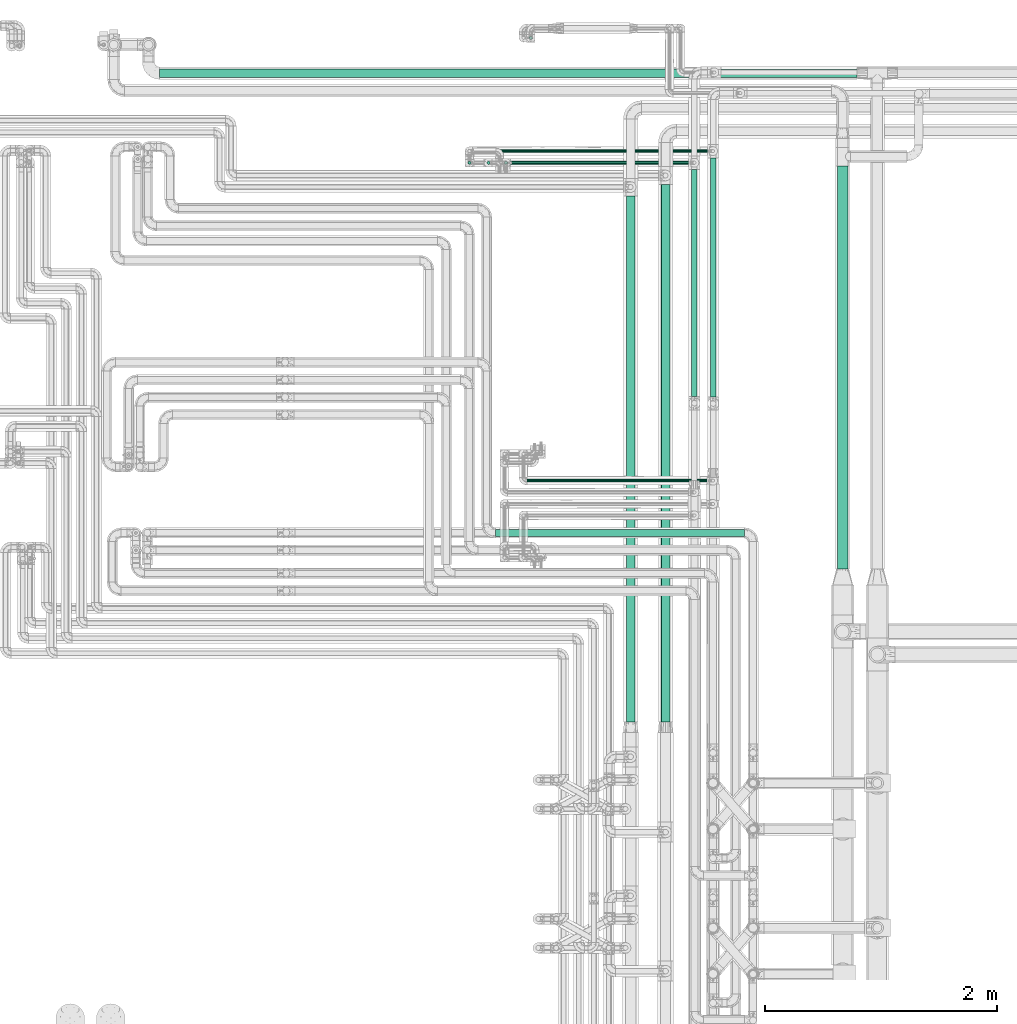
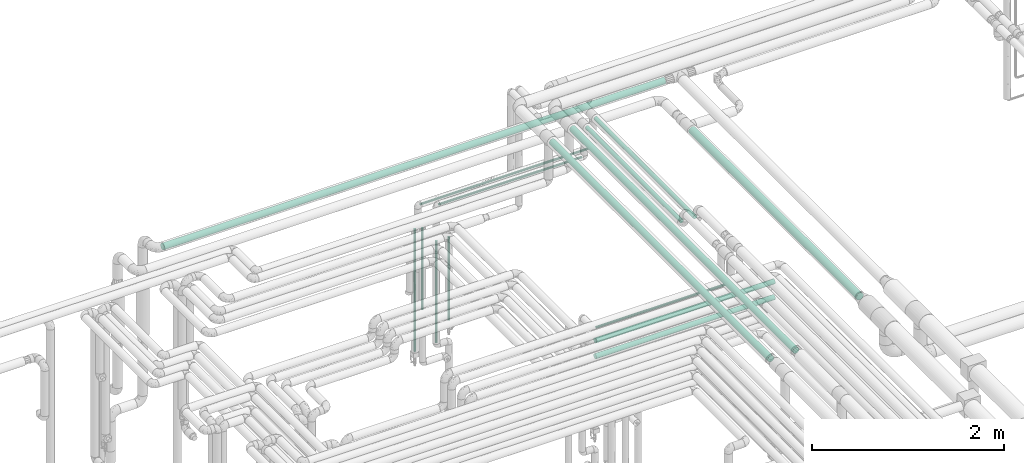
# One storey, part 534 of 827: 15 flow segments.
"""IFC2X3 building model written with IfcOpenShell, lengths in millimetres."""

from ifc_helpers import new_model, entity, si_unit, converted_unit, derived_unit, direction, frame, origin, origin_2d_with_axis, place, context, subcontext, project, spatial, circle, extrude, type_object, element, save


model = new_model("IFC2X3")

# Units and contexts
model_context = context("Model", 3, precision=0.01, world=origin(), true_north=direction((6.12303176911189e-17, 1.0)))
body_context = subcontext(model_context, "Body", "Model", "MODEL_VIEW")
ifc_project = project(units=[si_unit("LENGTHUNIT", "METRE", prefix="MILLI"), si_unit("AREAUNIT", "SQUARE_METRE"), si_unit("VOLUMEUNIT", "CUBIC_METRE"), converted_unit("PLANEANGLEUNIT", "DEGREE", entity("IfcRatioMeasure", 0.0174532925199433), si_unit("PLANEANGLEUNIT", "RADIAN"), dimensions=[0, 0, 0, 0, 0, 0, 0]), si_unit("MASSUNIT", "GRAM", prefix="KILO"), derived_unit("MASSDENSITYUNIT", [(si_unit("MASSUNIT", "GRAM", prefix="KILO"), 1), (si_unit("LENGTHUNIT", "METRE"), -3)]), derived_unit("MOMENTOFINERTIAUNIT", [(si_unit("LENGTHUNIT", "METRE"), 4)]), si_unit("TIMEUNIT", "SECOND"), si_unit("FREQUENCYUNIT", "HERTZ"), si_unit("THERMODYNAMICTEMPERATUREUNIT", "DEGREE_CELSIUS"), derived_unit("THERMALTRANSMITTANCEUNIT", [(si_unit("MASSUNIT", "GRAM", prefix="KILO"), 1), (si_unit("THERMODYNAMICTEMPERATUREUNIT", "KELVIN"), -1), (si_unit("TIMEUNIT", "SECOND"), -3)]), derived_unit("VOLUMETRICFLOWRATEUNIT", [(si_unit("LENGTHUNIT", "METRE"), 3), (si_unit("TIMEUNIT", "SECOND"), -1)]), derived_unit("MASSFLOWRATEUNIT", [(si_unit("MASSUNIT", "GRAM", prefix="KILO"), 1), (si_unit("TIMEUNIT", "SECOND"), -1)]), derived_unit("ROTATIONALFREQUENCYUNIT", [(si_unit("TIMEUNIT", "SECOND"), -1)]), si_unit("ELECTRICCURRENTUNIT", "AMPERE"), si_unit("ELECTRICVOLTAGEUNIT", "VOLT"), si_unit("POWERUNIT", "WATT"), si_unit("FORCEUNIT", "NEWTON", prefix="KILO"), si_unit("ILLUMINANCEUNIT", "LUX"), si_unit("LUMINOUSFLUXUNIT", "LUMEN"), si_unit("LUMINOUSINTENSITYUNIT", "CANDELA"), derived_unit("USERDEFINED", [(si_unit("MASSUNIT", "GRAM", prefix="KILO"), -1), (si_unit("LENGTHUNIT", "METRE"), -2), (si_unit("TIMEUNIT", "SECOND"), 3), (si_unit("LUMINOUSFLUXUNIT", "LUMEN"), 1)]), derived_unit("LINEARVELOCITYUNIT", [(si_unit("LENGTHUNIT", "METRE"), 1), (si_unit("TIMEUNIT", "SECOND"), -1)]), si_unit("PRESSUREUNIT", "PASCAL"), derived_unit("USERDEFINED", [(si_unit("LENGTHUNIT", "METRE"), -2), (si_unit("MASSUNIT", "GRAM", prefix="KILO"), 1), (si_unit("TIMEUNIT", "SECOND"), -2)]), derived_unit("LINEARFORCEUNIT", [(si_unit("MASSUNIT", "GRAM", prefix="KILO"), 1), (si_unit("LENGTHUNIT", "METRE"), 1), (si_unit("TIMEUNIT", "SECOND"), -2), (si_unit("LENGTHUNIT", "METRE"), -1)]), derived_unit("PLANARFORCEUNIT", [(si_unit("MASSUNIT", "GRAM", prefix="KILO"), 1), (si_unit("LENGTHUNIT", "METRE"), 1), (si_unit("TIMEUNIT", "SECOND"), -2), (si_unit("LENGTHUNIT", "METRE"), -2)])], contexts=[model_context])

# Site, building, storey
site_placement = place(None, origin())
site = spatial("IfcSite", under=ifc_project, at=site_placement, CompositionType="ELEMENT")
building_placement = place(site_placement, origin())
building = spatial("IfcBuilding", under=site, at=building_placement, CompositionType="ELEMENT")
storey_placement = place(building_placement, frame((0.0, 0.0, 28200.0)))
storey = spatial("IfcBuildingStorey", under=building, at=storey_placement, Name="08", CompositionType="ELEMENT", Elevation=28200.0)

# Flow segments
pipe_segment_type_1 = type_object("IfcPipeSegmentType", PredefinedType="NOTDEFINED")
flow_segment_1_placement = place(storey_placement, frame((31850.7, 19068.12, 2960.4)))
element("IfcFlowSegment", 1, at=flow_segment_1_placement, inside=storey, type_object=pipe_segment_type_1, context=body_context, shape_type="SweptSolid", body=[
    extrude(circle(Radius=38.0, at=origin_2d_with_axis()), frame((0.0, 39.6, 39.6), z_axis=(1.0, 0.0, 0.0), x_axis=(0.0, -1.0, 0.0)), (0.0, 0.0, 1.0), 6022.59656958631),
])
flow_segment_2_placement = place(storey_placement, frame((37702.2, 14827.72, 2853.86)))
element("IfcFlowSegment", 2, at=flow_segment_2_placement, inside=storey, type_object=pipe_segment_type_1, context=body_context, shape_type="SweptSolid", body=[
    extrude(circle(Radius=44.5, at=origin_2d_with_axis()), frame((46.1, 0.0, 46.1), z_axis=(0.0, 1.0, 3.91458551998914e-05), x_axis=(1.0, 0.0, 0.0)), (0.0, 0.0, 1.0), 3480.66550139349),
])
pipe_segment_type_2 = type_object("IfcPipeSegmentType", PredefinedType="NOTDEFINED")
flow_segment_3_placement = place(storey_placement, frame((35041.04, 19398.44, 367.5)))
element("IfcFlowSegment", 3, at=flow_segment_3_placement, inside=storey, type_object=pipe_segment_type_2, context=body_context, shape_type="SweptSolid", body=[
    extrude(circle(Radius=13.4, at=origin_2d_with_axis()), frame((15.0, 15.0, 0.0)), (0.0, 0.0, 1.0), 1553.40000000001),
])
flow_segment_4_placement = place(storey_placement, frame((34751.03, 15107.41, 2968.4)))
element("IfcFlowSegment", 4, at=flow_segment_4_placement, inside=storey, type_object=pipe_segment_type_2, context=body_context, shape_type="SweptSolid", body=[
    extrude(circle(Radius=30.0, at=origin_2d_with_axis()), frame((0.0, 31.6, 31.6), z_axis=(1.0, 0.0, 0.0), x_axis=(0.0, -1.0, 0.0)), (0.0, 0.0, 1.0), 2148.00000000003),
])
flow_segment_5_placement = place(storey_placement, frame((34751.03, 15107.41, 3168.4)))
element("IfcFlowSegment", 5, at=flow_segment_5_placement, inside=storey, type_object=pipe_segment_type_2, context=body_context, shape_type="SweptSolid", body=[
    extrude(circle(Radius=30.0, at=origin_2d_with_axis()), frame((0.0, 31.6, 31.6), z_axis=(1.0, 0.0, 0.0), x_axis=(0.0, -1.0, 0.0)), (0.0, 0.0, 1.0), 2148.00000000005),
])
flow_segment_6_placement = place(storey_placement, frame((36180.69, 13506.7, 3510.65)))
element("IfcFlowSegment", 6, at=flow_segment_6_placement, inside=storey, type_object=pipe_segment_type_2, context=body_context, shape_type="SweptSolid", body=[
    extrude(circle(Radius=37.75, at=origin_2d_with_axis()), frame((39.35, 0.0, 39.35), z_axis=(0.0, 1.0, 0.0), x_axis=(-1.0, 0.0, 0.0)), (0.0, 0.0, 1.0), 4642.2472086319),
])
flow_segment_7_placement = place(storey_placement, frame((35878.75, 13506.7, 3510.66)))
element("IfcFlowSegment", 7, at=flow_segment_7_placement, inside=storey, type_object=pipe_segment_type_2, context=body_context, shape_type="SweptSolid", body=[
    extrude(circle(Radius=37.75, at=origin_2d_with_axis()), frame((39.35, 0.0, 39.35), z_axis=(0.0, 1.0, 0.0), x_axis=(1.0, 0.0, 0.0)), (0.0, 0.0, 1.0), 4542.20661769207),
])
flow_segment_8_placement = place(storey_placement, frame((35021.98, 15575.04, 2985.0)))
element("IfcFlowSegment", 8, at=flow_segment_8_placement, inside=storey, type_object=pipe_segment_type_2, context=body_context, shape_type="SweptSolid", body=[
    extrude(circle(Radius=13.4, at=origin_2d_with_axis()), frame((0.0, 15.0, 15.0), z_axis=(1.0, 0.0, 0.0), x_axis=(0.0, 1.0, 0.0)), (0.0, 0.0, 1.0), 1578.55884471227),
])
flow_segment_9_placement = place(storey_placement, frame((36604.05, 16312.49, 3374.3)))
element("IfcFlowSegment", 9, at=flow_segment_9_placement, inside=storey, type_object=pipe_segment_type_2, context=body_context, shape_type="SweptSolid", body=[
    extrude(circle(Radius=24.0, at=origin_2d_with_axis()), frame((25.6, 0.0, 25.6), z_axis=(0.0, 1.0, 0.0), x_axis=(-1.0, 0.0, 0.0)), (0.0, 0.0, 1.0), 2065.41871271011),
])
flow_segment_10_placement = place(storey_placement, frame((36443.12, 16315.93, 3374.3)))
element("IfcFlowSegment", 10, at=flow_segment_10_placement, inside=storey, type_object=pipe_segment_type_2, context=body_context, shape_type="SweptSolid", body=[
    extrude(circle(Radius=24.0, at=origin_2d_with_axis()), frame((25.6, 0.0, 25.6), z_axis=(0.0, 1.0, 0.0), x_axis=(-1.0, 0.0, 0.0)), (0.0, 0.0, 1.0), 1961.97743456359),
])
flow_segment_11_placement = place(storey_placement, frame((34719.52, 18319.92, 2985.17)))
element("IfcFlowSegment", 11, at=flow_segment_11_placement, inside=storey, type_object=pipe_segment_type_2, context=body_context, shape_type="SweptSolid", body=[
    extrude(circle(Radius=13.4, at=origin_2d_with_axis()), frame((0.0, 15.0, 15.0), z_axis=(1.0, 0.0, 0.0), x_axis=(0.0, 1.0, 0.0)), (0.0, 0.0, 1.0), 1720.09204331245),
])
flow_segment_12_placement = place(storey_placement, frame((34554.49, 18419.91, 2985.17)))
element("IfcFlowSegment", 12, at=flow_segment_12_placement, inside=storey, type_object=pipe_segment_type_2, context=body_context, shape_type="SweptSolid", body=[
    extrude(circle(Radius=13.4, at=origin_2d_with_axis()), frame((0.0, 15.0, 15.0), z_axis=(1.0, 0.0, 0.0), x_axis=(0.0, -1.0, 0.0)), (0.0, 0.0, 1.0), 2046.05786972113),
])
flow_segment_13_placement = place(storey_placement, frame((34510.39, 18319.92, 1739.0)))
element("IfcFlowSegment", 13, at=flow_segment_13_placement, inside=storey, type_object=pipe_segment_type_2, context=body_context, shape_type="SweptSolid", body=[
    extrude(circle(Radius=13.4, at=origin_2d_with_axis()), frame((15.0, 15.0, 0.0)), (0.0, 0.0, 1.0), 1031.9),
])
flow_segment_14_placement = place(storey_placement, frame((34825.43, 18319.92, 1492.5)))
element("IfcFlowSegment", 14, at=flow_segment_14_placement, inside=storey, type_object=pipe_segment_type_2, context=body_context, shape_type="SweptSolid", body=[
    extrude(circle(Radius=13.4, at=origin_2d_with_axis()), frame((15.0, 15.0, 0.0), z_axis=(0.0, 0.0, 1.0), x_axis=(-1.0, 0.0, 0.0)), (0.0, 0.0, 1.0), 1058.40000000002),
])
flow_segment_15_placement = place(storey_placement, frame((34675.43, 18319.92, 1259.1)))
element("IfcFlowSegment", 15, at=flow_segment_15_placement, inside=storey, type_object=pipe_segment_type_2, context=body_context, shape_type="SweptSolid", body=[
    extrude(circle(Radius=13.4, at=origin_2d_with_axis()), frame((15.0, 15.0, 0.0), z_axis=(0.0, 0.0, 1.0), x_axis=(-1.0, 0.0, 0.0)), (0.0, 0.0, 1.0), 1291.90000000004),
])

save(model, "model.ifc")
